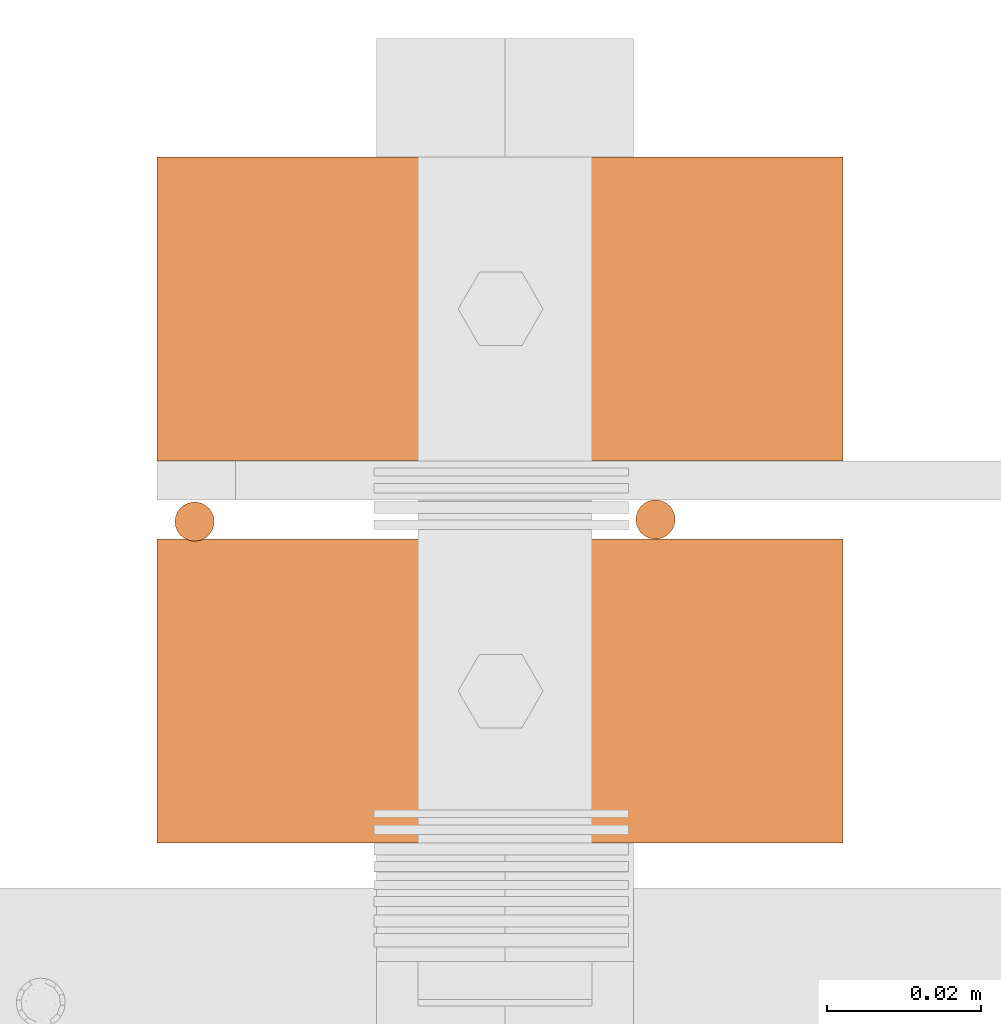
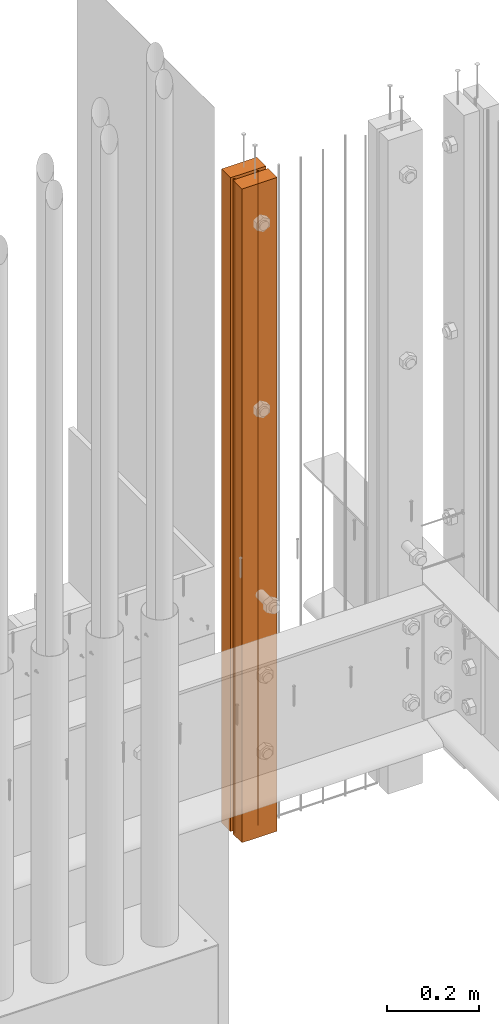
# One storey, part 9 of 44: 3 proxies.
"""IFC4 building model written with IfcOpenShell, lengths in feet."""

from ifc_helpers import new_model, entity, si_unit, converted_unit, derived_unit, direction, frame, frame_2d, origin, origin_2d_with_axis, place, context, subcontext, project, spatial, rectangle, circle, extrude, source, transform, mapped, material, type_object, type_shapes, element, save


model = new_model("IFC4")

# Units and contexts
model_context = context("Model", 3, precision=0.0001, world=origin(), true_north=direction((6.12303176911189e-17, 1.0)))
body_context = subcontext(model_context, "Body", "Model", "MODEL_VIEW")
ifc_project = project(units=[converted_unit("LENGTHUNIT", "FOOT", entity("IfcRatioMeasure", 0.3048), si_unit("LENGTHUNIT", "METRE"), dimensions=[1, 0, 0, 0, 0, 0, 0]), converted_unit("AREAUNIT", "SQUARE FOOT", entity("IfcRatioMeasure", 0.09290304), si_unit("AREAUNIT", "SQUARE_METRE"), dimensions=[2, 0, 0, 0, 0, 0, 0]), converted_unit("VOLUMEUNIT", "CUBIC FOOT", entity("IfcRatioMeasure", 0.028316846592), si_unit("VOLUMEUNIT", "CUBIC_METRE"), dimensions=[3, 0, 0, 0, 0, 0, 0]), converted_unit("PLANEANGLEUNIT", "DEGREE", entity("IfcRatioMeasure", 0.0174532925199433), si_unit("PLANEANGLEUNIT", "RADIAN"), dimensions=[0, 0, 0, 0, 0, 0, 0]), si_unit("MASSUNIT", "GRAM", prefix="KILO"), derived_unit("MASSDENSITYUNIT", [(si_unit("MASSUNIT", "GRAM", prefix="KILO"), 1), (si_unit("LENGTHUNIT", "METRE"), -3)]), derived_unit("MOMENTOFINERTIAUNIT", [(si_unit("LENGTHUNIT", "METRE"), 4)]), si_unit("TIMEUNIT", "SECOND"), si_unit("FREQUENCYUNIT", "HERTZ"), si_unit("THERMODYNAMICTEMPERATUREUNIT", "DEGREE_CELSIUS"), derived_unit("THERMALTRANSMITTANCEUNIT", [(si_unit("MASSUNIT", "GRAM", prefix="KILO"), 1), (si_unit("THERMODYNAMICTEMPERATUREUNIT", "KELVIN"), -1), (si_unit("TIMEUNIT", "SECOND"), -3)]), derived_unit("VOLUMETRICFLOWRATEUNIT", [(si_unit("LENGTHUNIT", "METRE"), 3), (si_unit("TIMEUNIT", "SECOND"), -1)]), si_unit("ELECTRICCURRENTUNIT", "AMPERE"), si_unit("ELECTRICVOLTAGEUNIT", "VOLT"), si_unit("POWERUNIT", "WATT"), si_unit("FORCEUNIT", "NEWTON"), si_unit("ILLUMINANCEUNIT", "LUX"), si_unit("LUMINOUSFLUXUNIT", "LUMEN"), si_unit("LUMINOUSINTENSITYUNIT", "CANDELA"), derived_unit("USERDEFINED", [(si_unit("MASSUNIT", "GRAM", prefix="KILO"), -1), (si_unit("LENGTHUNIT", "METRE"), -2), (si_unit("TIMEUNIT", "SECOND"), 3), (si_unit("LUMINOUSFLUXUNIT", "LUMEN"), 1)]), derived_unit("LINEARVELOCITYUNIT", [(si_unit("LENGTHUNIT", "METRE"), 1), (si_unit("TIMEUNIT", "SECOND"), -1)]), si_unit("PRESSUREUNIT", "PASCAL"), derived_unit("USERDEFINED", [(si_unit("LENGTHUNIT", "METRE"), -2), (si_unit("MASSUNIT", "GRAM", prefix="KILO"), 1), (si_unit("TIMEUNIT", "SECOND"), -2)]), derived_unit("LINEARFORCEUNIT", [(si_unit("MASSUNIT", "GRAM", prefix="KILO"), 1), (si_unit("LENGTHUNIT", "METRE"), 1), (si_unit("TIMEUNIT", "SECOND"), -2), (si_unit("LENGTHUNIT", "METRE"), -1)]), derived_unit("PLANARFORCEUNIT", [(si_unit("MASSUNIT", "GRAM", prefix="KILO"), 1), (si_unit("LENGTHUNIT", "METRE"), 1), (si_unit("TIMEUNIT", "SECOND"), -2), (si_unit("LENGTHUNIT", "METRE"), -2)])], contexts=[model_context])

# Site, building, storey
site_placement = place(None, origin())
site = spatial("IfcSite", under=ifc_project, at=site_placement, CompositionType="ELEMENT")
building_placement = place(site_placement, origin())
building = spatial("IfcBuilding", under=site, at=building_placement, CompositionType="ELEMENT")
storey_placement = place(building_placement, origin())
storey = spatial("IfcBuildingStorey", under=building, at=storey_placement, CompositionType="ELEMENT", Elevation=0.0)

# Proxies
ifc_material_1 = material(Name="(2) 2X4s - EXT STAIN - DARK", Category="Materials")
building_element_proxy_type_1 = type_object("IfcBuildingElementProxyType", Name="RAILING 38:RAILING 2", PredefinedType="NOTDEFINED", material=ifc_material_1)
shared_shape_1 = source(origin(), body_context, "Body", "SweptSolid", [
    extrude(rectangle(XDim=0.291666666666742, YDim=0.129166666666605, at=frame_2d((-1.13686837721616e-13, -4.44089209850063e-16), x_axis=(1.0, 0.0))), frame((0.145833333333485, 0.227083333333212, 0.0), z_axis=(0.0, 0.0, 1.0), x_axis=(-1.0, 0.0, 0.0)), (0.0, 0.0, 1.0), 5.70833333332643),
    extrude(rectangle(XDim=0.129166666666606, YDim=0.291666666666742, at=frame_2d((0.0, -1.13686837721616e-13), x_axis=(1.0, 0.0))), frame((0.145833333333485, 0.0645833333333039, 0.0), z_axis=(0.0, 0.0, 1.0), x_axis=(0.0, 1.0, 0.0)), (0.0, 0.0, 1.0), 5.70833333332643),
])
type_shapes(building_element_proxy_type_1, [shared_shape_1])
proxy_1_placement = place(storey_placement, frame((1492.50895604585, 4.75787225520081, 8.17708333334023)))
element("IfcBuildingElementProxy", 1, at=proxy_1_placement, inside=storey, type_object=building_element_proxy_type_1, material=ifc_material_1, Name="RAILING 38:RAILING 2", ObjectType="RAILING 38:RAILING 2", PredefinedType="NOTDEFINED", context=body_context, shape_type="MappedRepresentation", body=[
    mapped(shared_shape_1, transform((0.0, 0.0, 0.0), scale=1.0)),
])
ifc_material_2 = material(Category="Materials")
building_element_proxy_type_2 = type_object("IfcBuildingElementProxyType", Name="RAILING 41:RAILING 20", PredefinedType="NOTDEFINED", material=ifc_material_2)
shared_shape_2 = source(origin(), body_context, "Body", "SweptSolid", [
    extrude(circle(Radius=0.00833333333333333, at=origin_2d_with_axis()), frame((0.013567166128496, 0.0135671661283334, 0.0)), (0.0, 0.0, 1.0), 5.70833333333334),
])
type_shapes(building_element_proxy_type_2, [shared_shape_2])
proxy_2_placement = place(storey_placement, frame((1492.70737259517, 4.88185192676876, 8.17708333333332)))
element("IfcBuildingElementProxy", 2, at=proxy_2_placement, inside=storey, type_object=building_element_proxy_type_2, material=ifc_material_2, Name="RAILING 41:RAILING 20", ObjectType="RAILING 41:RAILING 20", PredefinedType="NOTDEFINED", context=body_context, shape_type="MappedRepresentation", body=[
    mapped(shared_shape_2, transform((0.0, 0.0, 0.0), scale=1.0)),
])
building_element_proxy_type_3 = type_object("IfcBuildingElementProxyType", Name="RAILING 42:RAILING 20", PredefinedType="NOTDEFINED", material=ifc_material_2)
shared_shape_3 = source(origin(), body_context, "Body", "SweptSolid", [
    extrude(circle(Radius=0.00833333333333333, at=origin_2d_with_axis()), frame((0.013567166128496, 0.0135671661283334, 0.0)), (0.0, 0.0, 1.0), 5.70833333333334),
])
type_shapes(building_element_proxy_type_3, [shared_shape_3])
proxy_3_placement = place(storey_placement, frame((1492.51130778512, 4.88094253557483, 8.17708333333332)))
element("IfcBuildingElementProxy", 3, at=proxy_3_placement, inside=storey, type_object=building_element_proxy_type_3, material=ifc_material_2, Name="RAILING 42:RAILING 20", ObjectType="RAILING 42:RAILING 20", PredefinedType="NOTDEFINED", context=body_context, shape_type="MappedRepresentation", body=[
    mapped(shared_shape_3, transform((0.0, 0.0, 0.0), scale=1.0)),
])

save(model, "model.ifc")
